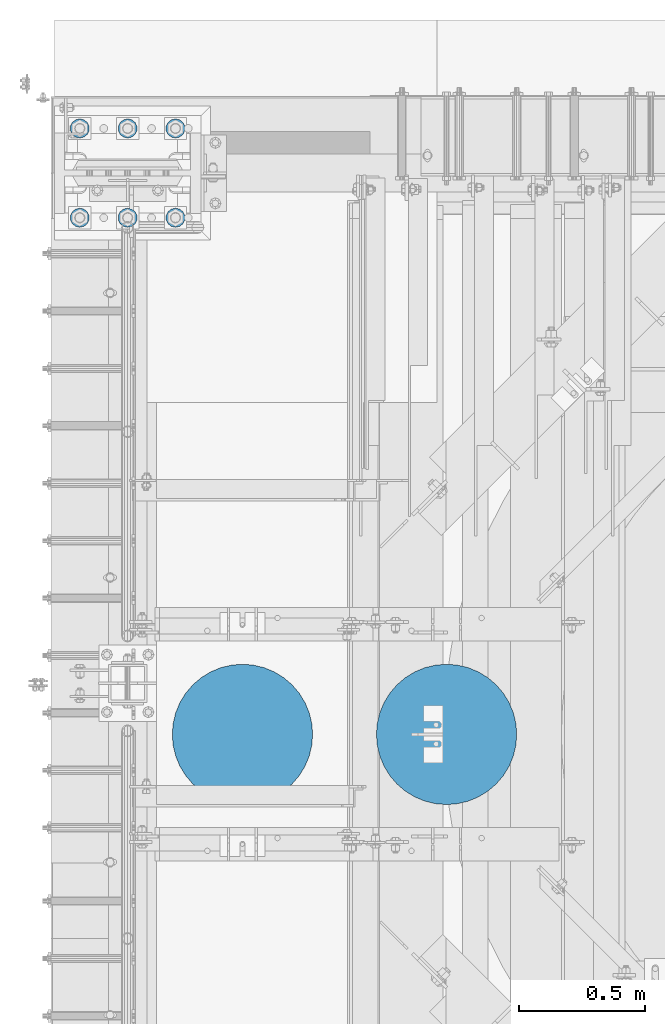
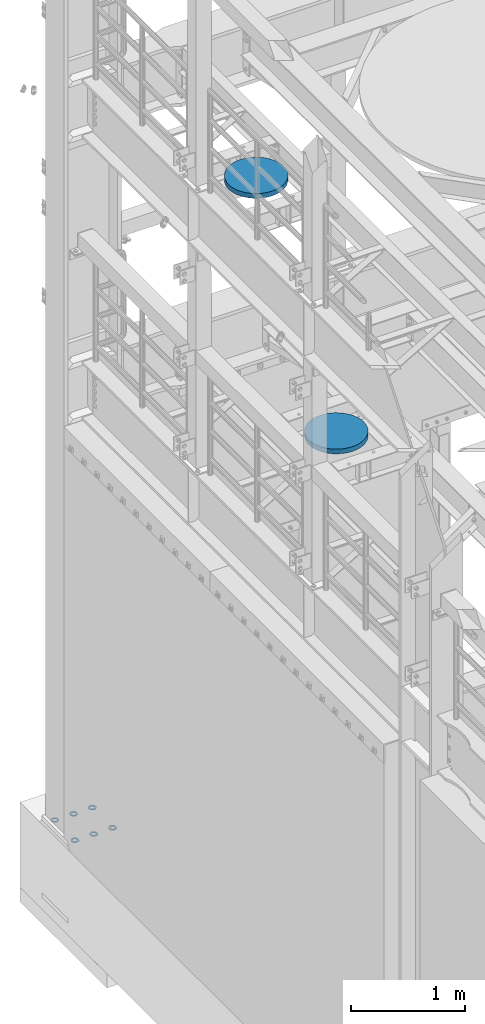
# One storey, part 851 of 1876: 8 columns, 3 elements without a shape of their own.
"""IFC2X3 building model written with IfcOpenShell, lengths in millimetres."""

from ifc_helpers import new_model, si_unit, frame, origin_with_axes, place, context, subcontext, project, spatial, faceted_brep, material, type_object, element, aggregate, save


model = new_model("IFC2X3")

# Units and contexts
model_context = context("Model", 3, precision=1e-05, world=origin_with_axes())
body_context = subcontext(model_context, "Body", "Model", "MODEL_VIEW")
ifc_project = project(units=[si_unit("LENGTHUNIT", "METRE", prefix="MILLI"), si_unit("AREAUNIT", "SQUARE_METRE"), si_unit("VOLUMEUNIT", "CUBIC_METRE"), si_unit("MASSUNIT", "GRAM", prefix="KILO"), si_unit("TIMEUNIT", "SECOND"), si_unit("PLANEANGLEUNIT", "RADIAN"), si_unit("SOLIDANGLEUNIT", "STERADIAN"), si_unit("THERMODYNAMICTEMPERATUREUNIT", "DEGREE_CELSIUS"), si_unit("LUMINOUSINTENSITYUNIT", "LUMEN")], contexts=[model_context])

# Site, building, storey
site_placement = place(None, origin_with_axes())
site = spatial("IfcSite", under=ifc_project, at=site_placement, CompositionType="ELEMENT")
building_placement = place(site_placement, origin_with_axes())
building = spatial("IfcBuilding", under=site, at=building_placement, Name="Undefined", CompositionType="ELEMENT")
storey_placement = place(building_placement, origin_with_axes())
storey = spatial("IfcBuildingStorey", under=building, at=storey_placement, Name="Undefined", CompositionType="ELEMENT", Elevation=0.0)

# Assembly, columns
assembly_1_placement = place(storey_placement, origin_with_axes())
assembly_1 = element("IfcElementAssembly", 1, at=assembly_1_placement, inside=storey, Name="TEMPLATE", AssemblyPlace="NOTDEFINED", PredefinedType="RIGID_FRAME")
ifc_material_1 = material(Name="STEEL/F436")
column_type_1 = type_object("IfcColumnType", Name="1-1/2_WASHER", PredefinedType="NOTDEFINED")
column_1_placement = place(assembly_1_placement, frame((190.5, 13538.2, 38.1), z_axis=(1.0, 0.0, 0.0), x_axis=(0.0, 0.0, -1.0)))
column_1 = element("IfcColumn", 2, at=column_1_placement, type_object=column_type_1, material=ifc_material_1, Name="WASHER", ObjectType="1-1/2_WASHER", context=body_context, shape_type="Brep", body=[
    faceted_brep([(0.0, -38.0999984741211, 0.0), (0.0, -34.3269124923136, -16.5309697983251), (4.7625, -34.3269124923136, -16.5309697983251), (4.7625, -38.0999984741211, 0.0), (0.0, -23.7549604994474, -29.787778289052), (4.7625, -23.7549604994474, -29.787778289052), (0.0, -8.4780472441962, -37.1447519665058), (4.7625, -8.4780472441962, -37.1447519665058), (0.0, 8.4780472441962, -37.1447519665058), (4.7625, 8.4780472441962, -37.1447519665058), (0.0, 23.7549604994474, -29.787778289052), (4.7625, 23.7549604994474, -29.787778289052), (0.0, 34.3269124923136, -16.5309697983251), (4.7625, 34.3269124923136, -16.5309697983251), (0.0, 38.0999984741211, 0.0), (4.7625, 38.0999984741211, 0.0), (0.0, 34.3269124923136, 16.5309697983251), (4.7625, 34.3269124923136, 16.5309697983251), (0.0, 23.7549604994474, 29.787778289052), (4.7625, 23.7549604994474, 29.787778289052), (0.0, 8.4780472441962, 37.1447519665058), (4.7625, 8.4780472441962, 37.1447519665058), (0.0, -8.4780472441962, 37.1447519665058), (4.7625, -8.4780472441962, 37.1447519665058), (0.0, -23.7549604994474, 29.787778289052), (4.7625, -23.7549604994474, 29.787778289052), (0.0, -34.3269124923136, 16.5309697983251), (4.7625, -34.3269124923136, 16.5309697983251), (0.0, 0.0, 20.6399993896484), (0.0, 8.95536011056538, 18.5959968835978), (4.7625, 8.95536011056538, 18.595996883598), (4.7625, 0.0, 20.6399993896484), (0.0, 16.1370013209489, 12.8688291298158), (4.7625, 16.1370013209489, 12.8688291298162), (0.0, 20.1225115123834, 4.59283194104228), (4.7625, 20.1225115123834, 4.59283194104222), (0.0, 20.1225115123834, -4.59283194104228), (4.7625, 20.1225115123834, -4.59283194104242), (0.0, 16.1370013209489, -12.8688291298167), (4.7625, 16.1370013209489, -12.8688291298163), (0.0, 8.95536011056538, -18.5959968835978), (4.7625, 8.95536011056538, -18.5959968835982), (0.0, 0.0, -20.6399993896484), (4.7625, 0.0, -20.6399993896484), (0.0, -8.95536011056538, -18.5959968835978), (4.7625, -8.95536011056538, -18.595996883598), (0.0, -16.1370013209489, -12.8688291298158), (4.7625, -16.1370013209489, -12.8688291298162), (0.0, -20.1225115123834, -4.59283194104228), (4.7625, -20.1225115123834, -4.59283194104222), (0.0, -20.1225115123834, 4.59283194104228), (4.7625, -20.1225115123834, 4.59283194104242), (0.0, -16.1370013209489, 12.8688291298167), (4.7625, -16.1370013209489, 12.8688291298163), (0.0, -8.95536011056538, 18.5959968835978), (4.7625, -8.95536011056538, 18.5959968835982)], [[[0, 1, 2, 3]], [[1, 4, 5, 2]], [[4, 6, 7, 5]], [[6, 8, 9, 7]], [[8, 10, 11, 9]], [[10, 12, 13, 11]], [[12, 14, 15, 13]], [[14, 16, 17, 15]], [[16, 18, 19, 17]], [[18, 20, 21, 19]], [[20, 22, 23, 21]], [[22, 24, 25, 23]], [[24, 26, 27, 25]], [[26, 0, 3, 27]], [[28, 29, 30, 31]], [[29, 32, 33, 30]], [[32, 34, 35, 33]], [[34, 36, 37, 35]], [[36, 38, 39, 37]], [[38, 40, 41, 39]], [[40, 42, 43, 41]], [[42, 44, 45, 43]], [[44, 46, 47, 45]], [[46, 48, 49, 47]], [[48, 50, 51, 49]], [[50, 52, 53, 51]], [[52, 54, 55, 53]], [[54, 28, 31, 55]], [[5, 7, 9, 11, 13, 15, 17, 19, 21, 23, 25, 27, 3, 2], [33, 35, 37, 39, 41, 43, 45, 47, 49, 51, 53, 55, 31, 30]], [[26, 24, 22, 20, 18, 16, 14, 12, 10, 8, 6, 4, 1, 0], [54, 52, 50, 48, 46, 44, 42, 40, 38, 36, 34, 32, 29, 28]]]),
])
column_2_placement = place(assembly_1_placement, frame((190.5, 13893.8, 38.1), z_axis=(-1.0, 0.0, 0.0), x_axis=(0.0, 0.0, -1.0)))
column_2 = element("IfcColumn", 3, at=column_2_placement, type_object=column_type_1, material=ifc_material_1, Name="WASHER", ObjectType="1-1/2_WASHER", context=body_context, shape_type="Brep", body=[
    faceted_brep([(0.0, -38.0999984741211, 0.0), (0.0, -34.3269124923136, -16.5309697983251), (4.7625, -34.3269124923136, -16.5309697983251), (4.7625, -38.0999984741211, 0.0), (0.0, -23.7549604994474, -29.787778289052), (4.7625, -23.7549604994474, -29.787778289052), (0.0, -8.4780472441962, -37.1447519665058), (4.7625, -8.4780472441962, -37.1447519665058), (0.0, 8.4780472441962, -37.1447519665058), (4.7625, 8.4780472441962, -37.1447519665058), (0.0, 23.7549604994474, -29.787778289052), (4.7625, 23.7549604994474, -29.787778289052), (0.0, 34.3269124923136, -16.5309697983251), (4.7625, 34.3269124923136, -16.5309697983251), (0.0, 38.0999984741211, 0.0), (4.7625, 38.0999984741211, 0.0), (0.0, 34.3269124923136, 16.5309697983251), (4.7625, 34.3269124923136, 16.5309697983251), (0.0, 23.7549604994474, 29.787778289052), (4.7625, 23.7549604994474, 29.787778289052), (0.0, 8.4780472441962, 37.1447519665058), (4.7625, 8.4780472441962, 37.1447519665058), (0.0, -8.4780472441962, 37.1447519665058), (4.7625, -8.4780472441962, 37.1447519665058), (0.0, -23.7549604994474, 29.787778289052), (4.7625, -23.7549604994474, 29.787778289052), (0.0, -34.3269124923136, 16.5309697983251), (4.7625, -34.3269124923136, 16.5309697983251), (0.0, 0.0, 20.6399993896484), (0.0, 8.95536011056538, 18.5959968835978), (4.7625, 8.95536011056538, 18.595996883598), (4.7625, 0.0, 20.6399993896484), (0.0, 16.1370013209489, 12.8688291298158), (4.7625, 16.1370013209489, 12.8688291298162), (0.0, 20.1225115123834, 4.59283194104228), (4.7625, 20.1225115123834, 4.59283194104222), (0.0, 20.1225115123834, -4.59283194104228), (4.7625, 20.1225115123834, -4.59283194104242), (0.0, 16.1370013209489, -12.8688291298167), (4.7625, 16.1370013209489, -12.8688291298163), (0.0, 8.95536011056538, -18.5959968835978), (4.7625, 8.95536011056538, -18.5959968835982), (0.0, 0.0, -20.6399993896484), (4.7625, 0.0, -20.6399993896484), (0.0, -8.95536011056538, -18.5959968835978), (4.7625, -8.95536011056538, -18.595996883598), (0.0, -16.1370013209489, -12.8688291298158), (4.7625, -16.1370013209489, -12.8688291298162), (0.0, -20.1225115123834, -4.59283194104228), (4.7625, -20.1225115123834, -4.59283194104222), (0.0, -20.1225115123834, 4.59283194104228), (4.7625, -20.1225115123834, 4.59283194104242), (0.0, -16.1370013209489, 12.8688291298167), (4.7625, -16.1370013209489, 12.8688291298163), (0.0, -8.95536011056538, 18.5959968835978), (4.7625, -8.95536011056538, 18.5959968835982)], [[[0, 1, 2, 3]], [[1, 4, 5, 2]], [[4, 6, 7, 5]], [[6, 8, 9, 7]], [[8, 10, 11, 9]], [[10, 12, 13, 11]], [[12, 14, 15, 13]], [[14, 16, 17, 15]], [[16, 18, 19, 17]], [[18, 20, 21, 19]], [[20, 22, 23, 21]], [[22, 24, 25, 23]], [[24, 26, 27, 25]], [[26, 0, 3, 27]], [[28, 29, 30, 31]], [[29, 32, 33, 30]], [[32, 34, 35, 33]], [[34, 36, 37, 35]], [[36, 38, 39, 37]], [[38, 40, 41, 39]], [[40, 42, 43, 41]], [[42, 44, 45, 43]], [[44, 46, 47, 45]], [[46, 48, 49, 47]], [[48, 50, 51, 49]], [[50, 52, 53, 51]], [[52, 54, 55, 53]], [[54, 28, 31, 55]], [[5, 7, 9, 11, 13, 15, 17, 19, 21, 23, 25, 27, 3, 2], [33, 35, 37, 39, 41, 43, 45, 47, 49, 51, 53, 55, 31, 30]], [[26, 24, 22, 20, 18, 16, 14, 12, 10, 8, 6, 4, 1, 0], [54, 52, 50, 48, 46, 44, 42, 40, 38, 36, 34, 32, 29, 28]]]),
])
column_3_placement = place(assembly_1_placement, frame((-2.8421709430404e-14, 13538.2, 38.1), z_axis=(1.0, 0.0, 0.0), x_axis=(0.0, 0.0, -1.0)))
column_3 = element("IfcColumn", 4, at=column_3_placement, type_object=column_type_1, material=ifc_material_1, Name="WASHER", ObjectType="1-1/2_WASHER", context=body_context, shape_type="Brep", body=[
    faceted_brep([(0.0, -38.0999984741211, 0.0), (0.0, -34.3269124923136, -16.5309697983251), (4.7625, -34.3269124923136, -16.5309697983251), (4.7625, -38.0999984741211, 0.0), (0.0, -23.7549604994474, -29.787778289052), (4.7625, -23.7549604994474, -29.787778289052), (0.0, -8.4780472441962, -37.1447519665058), (4.7625, -8.4780472441962, -37.1447519665058), (0.0, 8.4780472441962, -37.1447519665058), (4.7625, 8.4780472441962, -37.1447519665058), (0.0, 23.7549604994474, -29.787778289052), (4.7625, 23.7549604994474, -29.787778289052), (0.0, 34.3269124923136, -16.5309697983251), (4.7625, 34.3269124923136, -16.5309697983251), (0.0, 38.0999984741211, 0.0), (4.7625, 38.0999984741211, 0.0), (0.0, 34.3269124923136, 16.5309697983251), (4.7625, 34.3269124923136, 16.5309697983251), (0.0, 23.7549604994474, 29.787778289052), (4.7625, 23.7549604994474, 29.787778289052), (0.0, 8.4780472441962, 37.1447519665058), (4.7625, 8.4780472441962, 37.1447519665058), (0.0, -8.4780472441962, 37.1447519665058), (4.7625, -8.4780472441962, 37.1447519665058), (0.0, -23.7549604994474, 29.787778289052), (4.7625, -23.7549604994474, 29.787778289052), (0.0, -34.3269124923136, 16.5309697983251), (4.7625, -34.3269124923136, 16.5309697983251), (0.0, 0.0, 20.6399993896484), (0.0, 8.95536011056538, 18.5959968835978), (4.7625, 8.95536011056538, 18.595996883598), (4.7625, 0.0, 20.6399993896484), (0.0, 16.1370013209489, 12.8688291298158), (4.7625, 16.1370013209489, 12.8688291298162), (0.0, 20.1225115123834, 4.59283194104228), (4.7625, 20.1225115123834, 4.59283194104222), (0.0, 20.1225115123834, -4.59283194104228), (4.7625, 20.1225115123834, -4.59283194104242), (0.0, 16.1370013209489, -12.8688291298167), (4.7625, 16.1370013209489, -12.8688291298163), (0.0, 8.95536011056538, -18.5959968835978), (4.7625, 8.95536011056538, -18.5959968835982), (0.0, 0.0, -20.6399993896484), (4.7625, 0.0, -20.6399993896484), (0.0, -8.95536011056538, -18.5959968835978), (4.7625, -8.95536011056538, -18.595996883598), (0.0, -16.1370013209489, -12.8688291298158), (4.7625, -16.1370013209489, -12.8688291298162), (0.0, -20.1225115123834, -4.59283194104228), (4.7625, -20.1225115123834, -4.59283194104222), (0.0, -20.1225115123834, 4.59283194104228), (4.7625, -20.1225115123834, 4.59283194104242), (0.0, -16.1370013209489, 12.8688291298167), (4.7625, -16.1370013209489, 12.8688291298163), (0.0, -8.95536011056538, 18.5959968835978), (4.7625, -8.95536011056538, 18.5959968835982)], [[[0, 1, 2, 3]], [[1, 4, 5, 2]], [[4, 6, 7, 5]], [[6, 8, 9, 7]], [[8, 10, 11, 9]], [[10, 12, 13, 11]], [[12, 14, 15, 13]], [[14, 16, 17, 15]], [[16, 18, 19, 17]], [[18, 20, 21, 19]], [[20, 22, 23, 21]], [[22, 24, 25, 23]], [[24, 26, 27, 25]], [[26, 0, 3, 27]], [[28, 29, 30, 31]], [[29, 32, 33, 30]], [[32, 34, 35, 33]], [[34, 36, 37, 35]], [[36, 38, 39, 37]], [[38, 40, 41, 39]], [[40, 42, 43, 41]], [[42, 44, 45, 43]], [[44, 46, 47, 45]], [[46, 48, 49, 47]], [[48, 50, 51, 49]], [[50, 52, 53, 51]], [[52, 54, 55, 53]], [[54, 28, 31, 55]], [[5, 7, 9, 11, 13, 15, 17, 19, 21, 23, 25, 27, 3, 2], [33, 35, 37, 39, 41, 43, 45, 47, 49, 51, 53, 55, 31, 30]], [[26, 24, 22, 20, 18, 16, 14, 12, 10, 8, 6, 4, 1, 0], [54, 52, 50, 48, 46, 44, 42, 40, 38, 36, 34, 32, 29, 28]]]),
])
column_4_placement = place(assembly_1_placement, frame((-2.8421709430404e-14, 13893.8, 38.1), z_axis=(-1.0, 0.0, 0.0), x_axis=(0.0, 0.0, -1.0)))
column_4 = element("IfcColumn", 5, at=column_4_placement, type_object=column_type_1, material=ifc_material_1, Name="WASHER", ObjectType="1-1/2_WASHER", context=body_context, shape_type="Brep", body=[
    faceted_brep([(0.0, -38.0999984741211, 0.0), (0.0, -34.3269124923136, -16.5309697983251), (4.7625, -34.3269124923136, -16.5309697983251), (4.7625, -38.0999984741211, 0.0), (0.0, -23.7549604994474, -29.787778289052), (4.7625, -23.7549604994474, -29.787778289052), (0.0, -8.4780472441962, -37.1447519665058), (4.7625, -8.4780472441962, -37.1447519665058), (0.0, 8.4780472441962, -37.1447519665058), (4.7625, 8.4780472441962, -37.1447519665058), (0.0, 23.7549604994474, -29.787778289052), (4.7625, 23.7549604994474, -29.787778289052), (0.0, 34.3269124923136, -16.5309697983251), (4.7625, 34.3269124923136, -16.5309697983251), (0.0, 38.0999984741211, 0.0), (4.7625, 38.0999984741211, 0.0), (0.0, 34.3269124923136, 16.5309697983251), (4.7625, 34.3269124923136, 16.5309697983251), (0.0, 23.7549604994474, 29.787778289052), (4.7625, 23.7549604994474, 29.787778289052), (0.0, 8.4780472441962, 37.1447519665058), (4.7625, 8.4780472441962, 37.1447519665058), (0.0, -8.4780472441962, 37.1447519665058), (4.7625, -8.4780472441962, 37.1447519665058), (0.0, -23.7549604994474, 29.787778289052), (4.7625, -23.7549604994474, 29.787778289052), (0.0, -34.3269124923136, 16.5309697983251), (4.7625, -34.3269124923136, 16.5309697983251), (0.0, 0.0, 20.6399993896484), (0.0, 8.95536011056538, 18.5959968835978), (4.7625, 8.95536011056538, 18.595996883598), (4.7625, 0.0, 20.6399993896484), (0.0, 16.1370013209489, 12.8688291298158), (4.7625, 16.1370013209489, 12.8688291298162), (0.0, 20.1225115123834, 4.59283194104228), (4.7625, 20.1225115123834, 4.59283194104222), (0.0, 20.1225115123834, -4.59283194104228), (4.7625, 20.1225115123834, -4.59283194104242), (0.0, 16.1370013209489, -12.8688291298167), (4.7625, 16.1370013209489, -12.8688291298163), (0.0, 8.95536011056538, -18.5959968835978), (4.7625, 8.95536011056538, -18.5959968835982), (0.0, 0.0, -20.6399993896484), (4.7625, 0.0, -20.6399993896484), (0.0, -8.95536011056538, -18.5959968835978), (4.7625, -8.95536011056538, -18.595996883598), (0.0, -16.1370013209489, -12.8688291298158), (4.7625, -16.1370013209489, -12.8688291298162), (0.0, -20.1225115123834, -4.59283194104228), (4.7625, -20.1225115123834, -4.59283194104222), (0.0, -20.1225115123834, 4.59283194104228), (4.7625, -20.1225115123834, 4.59283194104242), (0.0, -16.1370013209489, 12.8688291298167), (4.7625, -16.1370013209489, 12.8688291298163), (0.0, -8.95536011056538, 18.5959968835978), (4.7625, -8.95536011056538, 18.5959968835982)], [[[0, 1, 2, 3]], [[1, 4, 5, 2]], [[4, 6, 7, 5]], [[6, 8, 9, 7]], [[8, 10, 11, 9]], [[10, 12, 13, 11]], [[12, 14, 15, 13]], [[14, 16, 17, 15]], [[16, 18, 19, 17]], [[18, 20, 21, 19]], [[20, 22, 23, 21]], [[22, 24, 25, 23]], [[24, 26, 27, 25]], [[26, 0, 3, 27]], [[28, 29, 30, 31]], [[29, 32, 33, 30]], [[32, 34, 35, 33]], [[34, 36, 37, 35]], [[36, 38, 39, 37]], [[38, 40, 41, 39]], [[40, 42, 43, 41]], [[42, 44, 45, 43]], [[44, 46, 47, 45]], [[46, 48, 49, 47]], [[48, 50, 51, 49]], [[50, 52, 53, 51]], [[52, 54, 55, 53]], [[54, 28, 31, 55]], [[5, 7, 9, 11, 13, 15, 17, 19, 21, 23, 25, 27, 3, 2], [33, 35, 37, 39, 41, 43, 45, 47, 49, 51, 53, 55, 31, 30]], [[26, 24, 22, 20, 18, 16, 14, 12, 10, 8, 6, 4, 1, 0], [54, 52, 50, 48, 46, 44, 42, 40, 38, 36, 34, 32, 29, 28]]]),
])
column_5_placement = place(assembly_1_placement, frame((-190.5, 13538.2, 38.1), z_axis=(1.0, 0.0, 0.0), x_axis=(0.0, 0.0, -1.0)))
column_5 = element("IfcColumn", 6, at=column_5_placement, type_object=column_type_1, material=ifc_material_1, Name="WASHER", ObjectType="1-1/2_WASHER", context=body_context, shape_type="Brep", body=[
    faceted_brep([(0.0, -38.0999984741211, 0.0), (0.0, -34.3269124923136, -16.5309697983251), (4.7625, -34.3269124923136, -16.5309697983251), (4.7625, -38.0999984741211, 0.0), (0.0, -23.7549604994474, -29.787778289052), (4.7625, -23.7549604994474, -29.787778289052), (0.0, -8.4780472441962, -37.1447519665058), (4.7625, -8.4780472441962, -37.1447519665058), (0.0, 8.4780472441962, -37.1447519665058), (4.7625, 8.4780472441962, -37.1447519665058), (0.0, 23.7549604994474, -29.787778289052), (4.7625, 23.7549604994474, -29.787778289052), (0.0, 34.3269124923136, -16.5309697983251), (4.7625, 34.3269124923136, -16.5309697983251), (0.0, 38.0999984741211, 0.0), (4.7625, 38.0999984741211, 0.0), (0.0, 34.3269124923136, 16.5309697983251), (4.7625, 34.3269124923136, 16.5309697983251), (0.0, 23.7549604994474, 29.787778289052), (4.7625, 23.7549604994474, 29.787778289052), (0.0, 8.4780472441962, 37.1447519665058), (4.7625, 8.4780472441962, 37.1447519665058), (0.0, -8.4780472441962, 37.1447519665058), (4.7625, -8.4780472441962, 37.1447519665058), (0.0, -23.7549604994474, 29.787778289052), (4.7625, -23.7549604994474, 29.787778289052), (0.0, -34.3269124923136, 16.5309697983251), (4.7625, -34.3269124923136, 16.5309697983251), (0.0, 0.0, 20.6399993896484), (0.0, 8.95536011056538, 18.5959968835978), (4.7625, 8.95536011056538, 18.595996883598), (4.7625, 0.0, 20.6399993896484), (0.0, 16.1370013209489, 12.8688291298158), (4.7625, 16.1370013209489, 12.8688291298162), (0.0, 20.1225115123834, 4.59283194104228), (4.7625, 20.1225115123834, 4.59283194104222), (0.0, 20.1225115123834, -4.59283194104228), (4.7625, 20.1225115123834, -4.59283194104242), (0.0, 16.1370013209489, -12.8688291298167), (4.7625, 16.1370013209489, -12.8688291298163), (0.0, 8.95536011056538, -18.5959968835978), (4.7625, 8.95536011056538, -18.5959968835982), (0.0, 0.0, -20.6399993896484), (4.7625, 0.0, -20.6399993896484), (0.0, -8.95536011056538, -18.5959968835978), (4.7625, -8.95536011056538, -18.595996883598), (0.0, -16.1370013209489, -12.8688291298158), (4.7625, -16.1370013209489, -12.8688291298162), (0.0, -20.1225115123834, -4.59283194104228), (4.7625, -20.1225115123834, -4.59283194104222), (0.0, -20.1225115123834, 4.59283194104228), (4.7625, -20.1225115123834, 4.59283194104242), (0.0, -16.1370013209489, 12.8688291298167), (4.7625, -16.1370013209489, 12.8688291298163), (0.0, -8.95536011056538, 18.5959968835978), (4.7625, -8.95536011056538, 18.5959968835982)], [[[0, 1, 2, 3]], [[1, 4, 5, 2]], [[4, 6, 7, 5]], [[6, 8, 9, 7]], [[8, 10, 11, 9]], [[10, 12, 13, 11]], [[12, 14, 15, 13]], [[14, 16, 17, 15]], [[16, 18, 19, 17]], [[18, 20, 21, 19]], [[20, 22, 23, 21]], [[22, 24, 25, 23]], [[24, 26, 27, 25]], [[26, 0, 3, 27]], [[28, 29, 30, 31]], [[29, 32, 33, 30]], [[32, 34, 35, 33]], [[34, 36, 37, 35]], [[36, 38, 39, 37]], [[38, 40, 41, 39]], [[40, 42, 43, 41]], [[42, 44, 45, 43]], [[44, 46, 47, 45]], [[46, 48, 49, 47]], [[48, 50, 51, 49]], [[50, 52, 53, 51]], [[52, 54, 55, 53]], [[54, 28, 31, 55]], [[5, 7, 9, 11, 13, 15, 17, 19, 21, 23, 25, 27, 3, 2], [33, 35, 37, 39, 41, 43, 45, 47, 49, 51, 53, 55, 31, 30]], [[26, 24, 22, 20, 18, 16, 14, 12, 10, 8, 6, 4, 1, 0], [54, 52, 50, 48, 46, 44, 42, 40, 38, 36, 34, 32, 29, 28]]]),
])
column_6_placement = place(assembly_1_placement, frame((-190.5, 13893.8, 38.1), z_axis=(-1.0, 0.0, 0.0), x_axis=(0.0, 0.0, -1.0)))
column_6 = element("IfcColumn", 7, at=column_6_placement, type_object=column_type_1, material=ifc_material_1, Name="WASHER", ObjectType="1-1/2_WASHER", context=body_context, shape_type="Brep", body=[
    faceted_brep([(0.0, -38.0999984741211, 0.0), (0.0, -34.3269124923136, -16.5309697983251), (4.7625, -34.3269124923136, -16.5309697983251), (4.7625, -38.0999984741211, 0.0), (0.0, -23.7549604994474, -29.787778289052), (4.7625, -23.7549604994474, -29.787778289052), (0.0, -8.4780472441962, -37.1447519665058), (4.7625, -8.4780472441962, -37.1447519665058), (0.0, 8.4780472441962, -37.1447519665058), (4.7625, 8.4780472441962, -37.1447519665058), (0.0, 23.7549604994474, -29.787778289052), (4.7625, 23.7549604994474, -29.787778289052), (0.0, 34.3269124923136, -16.5309697983251), (4.7625, 34.3269124923136, -16.5309697983251), (0.0, 38.0999984741211, 0.0), (4.7625, 38.0999984741211, 0.0), (0.0, 34.3269124923136, 16.5309697983251), (4.7625, 34.3269124923136, 16.5309697983251), (0.0, 23.7549604994474, 29.787778289052), (4.7625, 23.7549604994474, 29.787778289052), (0.0, 8.4780472441962, 37.1447519665058), (4.7625, 8.4780472441962, 37.1447519665058), (0.0, -8.4780472441962, 37.1447519665058), (4.7625, -8.4780472441962, 37.1447519665058), (0.0, -23.7549604994474, 29.787778289052), (4.7625, -23.7549604994474, 29.787778289052), (0.0, -34.3269124923136, 16.5309697983251), (4.7625, -34.3269124923136, 16.5309697983251), (0.0, 0.0, 20.6399993896484), (0.0, 8.95536011056538, 18.5959968835978), (4.7625, 8.95536011056538, 18.595996883598), (4.7625, 0.0, 20.6399993896484), (0.0, 16.1370013209489, 12.8688291298158), (4.7625, 16.1370013209489, 12.8688291298162), (0.0, 20.1225115123834, 4.59283194104228), (4.7625, 20.1225115123834, 4.59283194104222), (0.0, 20.1225115123834, -4.59283194104228), (4.7625, 20.1225115123834, -4.59283194104242), (0.0, 16.1370013209489, -12.8688291298167), (4.7625, 16.1370013209489, -12.8688291298163), (0.0, 8.95536011056538, -18.5959968835978), (4.7625, 8.95536011056538, -18.5959968835982), (0.0, 0.0, -20.6399993896484), (4.7625, 0.0, -20.6399993896484), (0.0, -8.95536011056538, -18.5959968835978), (4.7625, -8.95536011056538, -18.595996883598), (0.0, -16.1370013209489, -12.8688291298158), (4.7625, -16.1370013209489, -12.8688291298162), (0.0, -20.1225115123834, -4.59283194104228), (4.7625, -20.1225115123834, -4.59283194104222), (0.0, -20.1225115123834, 4.59283194104228), (4.7625, -20.1225115123834, 4.59283194104242), (0.0, -16.1370013209489, 12.8688291298167), (4.7625, -16.1370013209489, 12.8688291298163), (0.0, -8.95536011056538, 18.5959968835978), (4.7625, -8.95536011056538, 18.5959968835982)], [[[0, 1, 2, 3]], [[1, 4, 5, 2]], [[4, 6, 7, 5]], [[6, 8, 9, 7]], [[8, 10, 11, 9]], [[10, 12, 13, 11]], [[12, 14, 15, 13]], [[14, 16, 17, 15]], [[16, 18, 19, 17]], [[18, 20, 21, 19]], [[20, 22, 23, 21]], [[22, 24, 25, 23]], [[24, 26, 27, 25]], [[26, 0, 3, 27]], [[28, 29, 30, 31]], [[29, 32, 33, 30]], [[32, 34, 35, 33]], [[34, 36, 37, 35]], [[36, 38, 39, 37]], [[38, 40, 41, 39]], [[40, 42, 43, 41]], [[42, 44, 45, 43]], [[44, 46, 47, 45]], [[46, 48, 49, 47]], [[48, 50, 51, 49]], [[50, 52, 53, 51]], [[52, 54, 55, 53]], [[54, 28, 31, 55]], [[5, 7, 9, 11, 13, 15, 17, 19, 21, 23, 25, 27, 3, 2], [33, 35, 37, 39, 41, 43, 45, 47, 49, 51, 53, 55, 31, 30]], [[26, 24, 22, 20, 18, 16, 14, 12, 10, 8, 6, 4, 1, 0], [54, 52, 50, 48, 46, 44, 42, 40, 38, 36, 34, 32, 29, 28]]]),
])
aggregate(assembly_1, [column_1, column_2, column_3, column_4, column_5, column_6])

# Assembly, column
assembly_2_placement = place(storey_placement, origin_with_axes())
assembly_2 = element("IfcElementAssembly", 8, at=assembly_2_placement, inside=storey, Name="COLUMN", AssemblyPlace="NOTDEFINED", PredefinedType="REINFORCEMENT_UNIT")
ifc_material_2 = material(Name="CONCRETE/3000")
column_type_2 = type_object("IfcColumnType", PredefinedType="NOTDEFINED")
column_7_placement = place(assembly_2_placement, frame((457.2, 11480.8, 8128.0), z_axis=(-1.0, 0.0, 0.0), x_axis=(0.0, 0.0, 1.0)))
column_7 = element("IfcColumn", 9, at=column_7_placement, type_object=column_type_2, material=ifc_material_2, Name="COLUMN", context=body_context, shape_type="Brep", body=[
    faceted_brep([(0.0, -279.4, 0.0), (0.0, -275.960122362281, -43.7077895322406), (50.7999999999993, -275.960122362281, -43.7077895322406), (50.7999999999993, -279.4, 0.0), (0.0, -265.725190652865, -86.3393482283603), (50.7999999999993, -265.725190652865, -86.3393482283603), (0.0, -248.947222858231, -126.844945627229), (50.7999999999993, -248.947222858231, -126.844945627229), (0.0, -226.03934822836, -164.227199490517), (50.7999999999993, -226.03934822836, -164.227199490517), (0.0, -197.565634663521, -197.565634663521), (50.7999999999993, -197.565634663521, -197.565634663521), (0.0, -164.227199490517, -226.03934822836), (50.7999999999993, -164.227199490517, -226.03934822836), (0.0, -126.84494562723, -248.94722285823), (50.7999999999993, -126.84494562723, -248.94722285823), (0.0, -86.3393482283609, -265.725190652866), (50.7999999999993, -86.3393482283609, -265.725190652866), (0.0, -43.70778953224, -275.960122362281), (50.7999999999993, -43.70778953224, -275.960122362281), (0.0, 0.0, -279.4), (50.7999999999993, 0.0, -279.4), (0.0, 43.70778953224, -275.960122362281), (50.7999999999993, 43.70778953224, -275.960122362281), (0.0, 86.3393482283609, -265.725190652866), (50.7999999999993, 86.3393482283609, -265.725190652866), (0.0, 126.84494562723, -248.94722285823), (50.7999999999993, 126.84494562723, -248.94722285823), (0.0, 164.227199490517, -226.03934822836), (50.7999999999993, 164.227199490517, -226.03934822836), (0.0, 197.565634663521, -197.565634663521), (50.7999999999993, 197.565634663521, -197.565634663521), (0.0, 226.03934822836, -164.227199490517), (50.7999999999993, 226.03934822836, -164.227199490517), (0.0, 248.947222858231, -126.844945627229), (50.7999999999993, 248.947222858231, -126.844945627229), (0.0, 265.725190652865, -86.3393482283602), (50.7999999999993, 265.725190652865, -86.3393482283602), (0.0, 275.960122362281, -43.7077895322404), (50.7999999999993, 275.960122362281, -43.7077895322404), (0.0, 279.4, 5.6843418860808e-14), (50.7999999999993, 279.4, 5.6843418860808e-14), (0.0, 275.960122362281, 43.7077895322406), (50.7999999999993, 275.960122362281, 43.7077895322406), (0.0, 265.725190652865, 86.3393482283603), (50.7999999999993, 265.725190652865, 86.3393482283603), (0.0, 248.947222858231, 126.844945627229), (50.7999999999993, 248.947222858231, 126.844945627229), (0.0, 226.03934822836, 164.227199490517), (50.7999999999993, 226.03934822836, 164.227199490517), (0.0, 197.565634663521, 197.565634663521), (50.7999999999993, 197.565634663521, 197.565634663521), (0.0, 164.227199490517, 226.03934822836), (50.7999999999993, 164.227199490517, 226.03934822836), (0.0, 126.84494562723, 248.94722285823), (50.7999999999993, 126.84494562723, 248.94722285823), (0.0, 86.3393482283609, 265.725190652866), (50.7999999999993, 86.3393482283609, 265.725190652866), (0.0, 43.70778953224, 275.960122362281), (50.7999999999993, 43.70778953224, 275.960122362281), (0.0, 0.0, 279.4), (50.7999999999993, 0.0, 279.4), (0.0, -43.70778953224, 275.960122362281), (50.7999999999993, -43.70778953224, 275.960122362281), (0.0, -86.3393482283609, 265.725190652866), (50.7999999999993, -86.3393482283609, 265.725190652866), (0.0, -126.84494562723, 248.94722285823), (50.7999999999993, -126.84494562723, 248.94722285823), (0.0, -164.227199490517, 226.03934822836), (50.7999999999993, -164.227199490517, 226.03934822836), (0.0, -197.565634663521, 197.565634663521), (50.7999999999993, -197.565634663521, 197.565634663521), (0.0, -226.03934822836, 164.227199490517), (50.7999999999993, -226.03934822836, 164.227199490517), (0.0, -248.947222858231, 126.844945627229), (50.7999999999993, -248.947222858231, 126.844945627229), (0.0, -265.725190652865, 86.3393482283603), (50.7999999999993, -265.725190652865, 86.3393482283603), (0.0, -275.960122362281, 43.7077895322405), (50.7999999999993, -275.960122362281, 43.7077895322405)], [[[0, 1, 2, 3]], [[1, 4, 5, 2]], [[4, 6, 7, 5]], [[6, 8, 9, 7]], [[8, 10, 11, 9]], [[10, 12, 13, 11]], [[12, 14, 15, 13]], [[14, 16, 17, 15]], [[16, 18, 19, 17]], [[18, 20, 21, 19]], [[20, 22, 23, 21]], [[22, 24, 25, 23]], [[24, 26, 27, 25]], [[26, 28, 29, 27]], [[28, 30, 31, 29]], [[30, 32, 33, 31]], [[32, 34, 35, 33]], [[34, 36, 37, 35]], [[36, 38, 39, 37]], [[38, 40, 41, 39]], [[40, 42, 43, 41]], [[42, 44, 45, 43]], [[44, 46, 47, 45]], [[46, 48, 49, 47]], [[48, 50, 51, 49]], [[50, 52, 53, 51]], [[52, 54, 55, 53]], [[54, 56, 57, 55]], [[56, 58, 59, 57]], [[58, 60, 61, 59]], [[60, 62, 63, 61]], [[62, 64, 65, 63]], [[64, 66, 67, 65]], [[66, 68, 69, 67]], [[68, 70, 71, 69]], [[70, 72, 73, 71]], [[72, 74, 75, 73]], [[74, 76, 77, 75]], [[76, 78, 79, 77]], [[78, 0, 3, 79]], [[5, 7, 9, 11, 13, 15, 17, 19, 21, 23, 25, 27, 29, 31, 33, 35, 37, 39, 41, 43, 45, 47, 49, 51, 53, 55, 57, 59, 61, 63, 65, 67, 69, 71, 73, 75, 77, 79, 3, 2]], [[78, 76, 74, 72, 70, 68, 66, 64, 62, 60, 58, 56, 54, 52, 50, 48, 46, 44, 42, 40, 38, 36, 34, 32, 30, 28, 26, 24, 22, 20, 18, 16, 14, 12, 10, 8, 6, 4, 1, 0]]]),
])
aggregate(assembly_2, [column_7])

assembly_3_placement = place(storey_placement, origin_with_axes())
assembly_3 = element("IfcElementAssembly", 10, at=assembly_3_placement, inside=storey, Name="COLUMN", AssemblyPlace="NOTDEFINED", PredefinedType="REINFORCEMENT_UNIT")
column_8_placement = place(assembly_3_placement, frame((1270.0, 11480.8, 5105.4), z_axis=(-1.0, 0.0, 0.0), x_axis=(0.0, 0.0, 1.0)))
column_8 = element("IfcColumn", 11, at=column_8_placement, type_object=column_type_2, material=ifc_material_2, Name="COLUMN", context=body_context, shape_type="Brep", body=[
    faceted_brep([(0.0, -279.4, 0.0), (0.0, -275.960122362281, -43.7077895322406), (50.7999999999993, -275.960122362281, -43.7077895322406), (50.7999999999993, -279.4, 0.0), (0.0, -265.725190652865, -86.3393482283603), (50.7999999999993, -265.725190652865, -86.3393482283603), (0.0, -248.947222858231, -126.844945627229), (50.7999999999993, -248.947222858231, -126.844945627229), (0.0, -226.03934822836, -164.227199490517), (50.7999999999993, -226.03934822836, -164.227199490517), (0.0, -197.565634663521, -197.565634663521), (50.7999999999993, -197.565634663521, -197.565634663521), (0.0, -164.227199490517, -226.03934822836), (50.7999999999993, -164.227199490517, -226.03934822836), (0.0, -126.84494562723, -248.94722285823), (50.7999999999993, -126.84494562723, -248.94722285823), (0.0, -86.3393482283609, -265.725190652866), (50.7999999999993, -86.3393482283609, -265.725190652866), (0.0, -43.70778953224, -275.960122362281), (50.7999999999993, -43.70778953224, -275.960122362281), (0.0, 0.0, -279.4), (50.7999999999993, 0.0, -279.4), (0.0, 43.70778953224, -275.960122362281), (50.7999999999993, 43.70778953224, -275.960122362281), (0.0, 86.3393482283609, -265.725190652866), (50.7999999999993, 86.3393482283609, -265.725190652866), (0.0, 126.84494562723, -248.94722285823), (50.7999999999993, 126.84494562723, -248.94722285823), (0.0, 164.227199490517, -226.03934822836), (50.7999999999993, 164.227199490517, -226.03934822836), (0.0, 197.565634663521, -197.565634663521), (50.7999999999993, 197.565634663521, -197.565634663521), (0.0, 226.03934822836, -164.227199490517), (50.7999999999993, 226.03934822836, -164.227199490517), (0.0, 248.947222858231, -126.844945627229), (50.7999999999993, 248.947222858231, -126.844945627229), (0.0, 265.725190652865, -86.3393482283602), (50.7999999999993, 265.725190652865, -86.3393482283602), (0.0, 275.960122362281, -43.7077895322404), (50.7999999999993, 275.960122362281, -43.7077895322404), (0.0, 279.4, 5.6843418860808e-14), (50.7999999999993, 279.4, 5.6843418860808e-14), (0.0, 275.960122362281, 43.7077895322406), (50.7999999999993, 275.960122362281, 43.7077895322406), (0.0, 265.725190652865, 86.3393482283603), (50.7999999999993, 265.725190652865, 86.3393482283603), (0.0, 248.947222858231, 126.844945627229), (50.7999999999993, 248.947222858231, 126.844945627229), (0.0, 226.03934822836, 164.227199490517), (50.7999999999993, 226.03934822836, 164.227199490517), (0.0, 197.565634663521, 197.565634663521), (50.7999999999993, 197.565634663521, 197.565634663521), (0.0, 164.227199490517, 226.03934822836), (50.7999999999993, 164.227199490517, 226.03934822836), (0.0, 126.84494562723, 248.94722285823), (50.7999999999993, 126.84494562723, 248.94722285823), (0.0, 86.3393482283609, 265.725190652866), (50.7999999999993, 86.3393482283609, 265.725190652866), (0.0, 43.70778953224, 275.960122362281), (50.7999999999993, 43.70778953224, 275.960122362281), (0.0, 0.0, 279.4), (50.7999999999993, 0.0, 279.4), (0.0, -43.70778953224, 275.960122362281), (50.7999999999993, -43.70778953224, 275.960122362281), (0.0, -86.3393482283609, 265.725190652866), (50.7999999999993, -86.3393482283609, 265.725190652866), (0.0, -126.84494562723, 248.94722285823), (50.7999999999993, -126.84494562723, 248.94722285823), (0.0, -164.227199490517, 226.03934822836), (50.7999999999993, -164.227199490517, 226.03934822836), (0.0, -197.565634663521, 197.565634663521), (50.7999999999993, -197.565634663521, 197.565634663521), (0.0, -226.03934822836, 164.227199490517), (50.7999999999993, -226.03934822836, 164.227199490517), (0.0, -248.947222858231, 126.844945627229), (50.7999999999993, -248.947222858231, 126.844945627229), (0.0, -265.725190652865, 86.3393482283603), (50.7999999999993, -265.725190652865, 86.3393482283603), (0.0, -275.960122362281, 43.7077895322405), (50.7999999999993, -275.960122362281, 43.7077895322405)], [[[0, 1, 2, 3]], [[1, 4, 5, 2]], [[4, 6, 7, 5]], [[6, 8, 9, 7]], [[8, 10, 11, 9]], [[10, 12, 13, 11]], [[12, 14, 15, 13]], [[14, 16, 17, 15]], [[16, 18, 19, 17]], [[18, 20, 21, 19]], [[20, 22, 23, 21]], [[22, 24, 25, 23]], [[24, 26, 27, 25]], [[26, 28, 29, 27]], [[28, 30, 31, 29]], [[30, 32, 33, 31]], [[32, 34, 35, 33]], [[34, 36, 37, 35]], [[36, 38, 39, 37]], [[38, 40, 41, 39]], [[40, 42, 43, 41]], [[42, 44, 45, 43]], [[44, 46, 47, 45]], [[46, 48, 49, 47]], [[48, 50, 51, 49]], [[50, 52, 53, 51]], [[52, 54, 55, 53]], [[54, 56, 57, 55]], [[56, 58, 59, 57]], [[58, 60, 61, 59]], [[60, 62, 63, 61]], [[62, 64, 65, 63]], [[64, 66, 67, 65]], [[66, 68, 69, 67]], [[68, 70, 71, 69]], [[70, 72, 73, 71]], [[72, 74, 75, 73]], [[74, 76, 77, 75]], [[76, 78, 79, 77]], [[78, 0, 3, 79]], [[5, 7, 9, 11, 13, 15, 17, 19, 21, 23, 25, 27, 29, 31, 33, 35, 37, 39, 41, 43, 45, 47, 49, 51, 53, 55, 57, 59, 61, 63, 65, 67, 69, 71, 73, 75, 77, 79, 3, 2]], [[78, 76, 74, 72, 70, 68, 66, 64, 62, 60, 58, 56, 54, 52, 50, 48, 46, 44, 42, 40, 38, 36, 34, 32, 30, 28, 26, 24, 22, 20, 18, 16, 14, 12, 10, 8, 6, 4, 1, 0]]]),
])
aggregate(assembly_3, [column_8])

save(model, "model.ifc")
